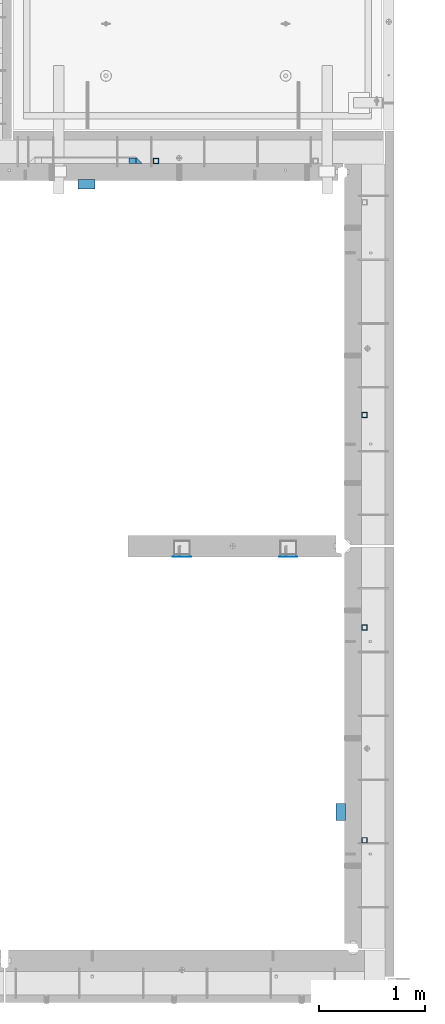
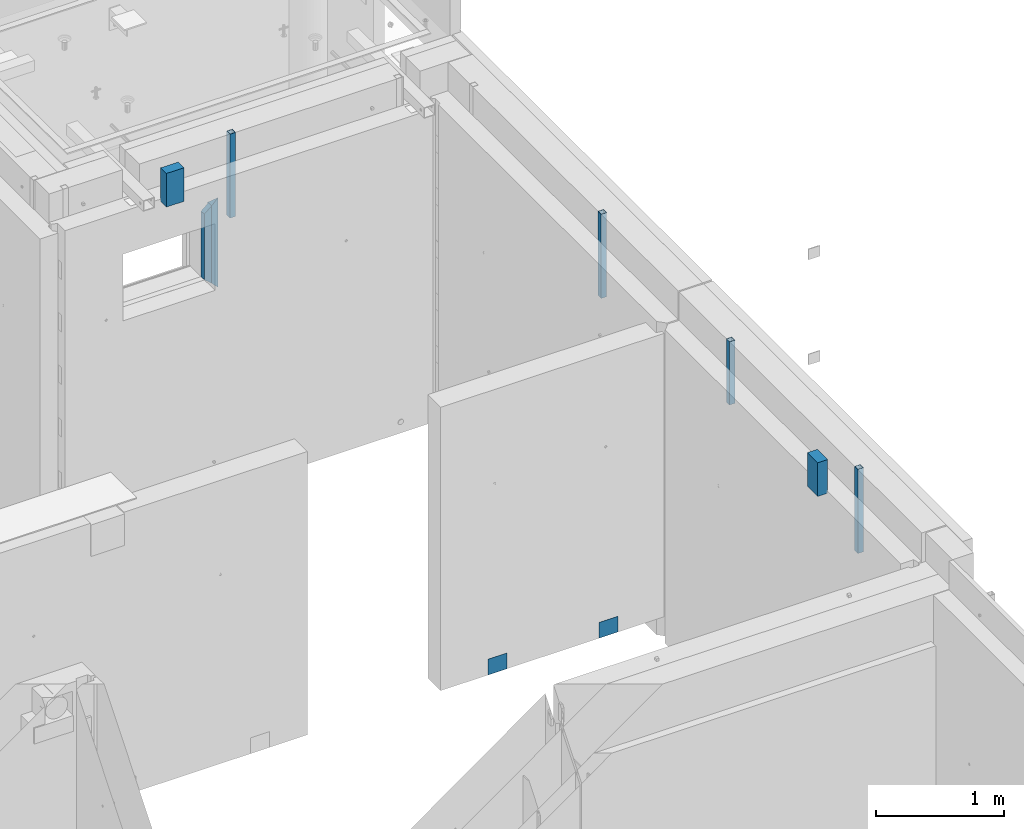
# One storey, part 21 of 264: 10 columns, 12 elements without a shape of their own.
"""IFC2X3 building model written with IfcOpenShell, lengths in millimetres."""

from ifc_helpers import new_model, si_unit, frame, origin_with_axes, place, context, subcontext, project, spatial, faceted_brep, material, type_object, element, aggregate, save


model = new_model("IFC2X3")

# Units and contexts
model_context = context("Model", 3, precision=1e-05, world=origin_with_axes())
body_context = subcontext(model_context, "Body", "Model", "MODEL_VIEW")
ifc_project = project(units=[si_unit("LENGTHUNIT", "METRE", prefix="MILLI"), si_unit("AREAUNIT", "SQUARE_METRE"), si_unit("VOLUMEUNIT", "CUBIC_METRE"), si_unit("MASSUNIT", "GRAM", prefix="KILO"), si_unit("TIMEUNIT", "SECOND"), si_unit("PLANEANGLEUNIT", "RADIAN"), si_unit("SOLIDANGLEUNIT", "STERADIAN"), si_unit("THERMODYNAMICTEMPERATUREUNIT", "DEGREE_CELSIUS"), si_unit("LUMINOUSINTENSITYUNIT", "LUMEN")], contexts=[model_context])

# Site, building, storey
site_placement = place(None, origin_with_axes())
site = spatial("IfcSite", under=ifc_project, at=site_placement, CompositionType="ELEMENT")
building_placement = place(site_placement, origin_with_axes())
building = spatial("IfcBuilding", under=site, at=building_placement, CompositionType="ELEMENT")
storey_placement = place(building_placement, origin_with_axes())
storey = spatial("IfcBuildingStorey", under=building, at=storey_placement, Name="K", CompositionType="ELEMENT", Elevation=0.0)

# Assemblies, columns
assembly_1_placement = place(storey_placement, origin_with_axes())
assembly_1 = element("IfcElementAssembly", 1, at=assembly_1_placement, inside=storey, AssemblyPlace="NOTDEFINED", PredefinedType="REINFORCEMENT_UNIT")
assembly_2_placement = place(assembly_1_placement, origin_with_axes())
assembly_2 = element("IfcElementAssembly", 2, at=assembly_2_placement, Name="Steel Assembly", AssemblyPlace="NOTDEFINED", PredefinedType="NOTDEFINED")
ifc_material_1 = material(Name="Undefined")
column_type_1 = type_object("IfcColumnType", PredefinedType="NOTDEFINED")
column_1_placement = place(assembly_2_placement, frame((33370.0003214753, 16881.0002441656, 78775.0000050936), z_axis=(0.0, -1.0, 0.0), x_axis=(0.0, 0.0, 1.0)))
column_1 = element("IfcColumn", 3, at=column_1_placement, type_object=column_type_1, material=ifc_material_1, Name="SPK3", context=body_context, shape_type="Brep", body=[
    faceted_brep([(0.0, 85.0, -1.0), (0.0, 85.0, 1.0), (150.0, 85.0, 1.0), (150.0, 85.0, -1.0), (0.0, -85.0, 1.0), (150.0, -85.0, 1.0), (0.0, -85.0, -1.0), (150.0, -85.0, -1.0)], [[[0, 1, 2, 3]], [[1, 4, 5, 2]], [[4, 6, 7, 5]], [[6, 0, 3, 7]], [[5, 7, 3, 2]], [[6, 4, 1, 0]]]),
])
aggregate(assembly_2, [column_1])
assembly_3_placement = place(assembly_1_placement, origin_with_axes())
assembly_3 = element("IfcElementAssembly", 4, at=assembly_3_placement, Name="Steel Assembly", AssemblyPlace="NOTDEFINED", PredefinedType="NOTDEFINED")
aggregate(assembly_1, [assembly_2, assembly_3])
column_2_placement = place(assembly_3_placement, frame((34370.0003214753, 16881.0002441656, 78775.0000050936), z_axis=(0.0, -1.0, 0.0), x_axis=(0.0, 0.0, 1.0)))
column_2 = element("IfcColumn", 5, at=column_2_placement, type_object=column_type_1, material=ifc_material_1, Name="SPK3", context=body_context, shape_type="Brep", body=[
    faceted_brep([(0.0, 85.0, -1.0), (0.0, 85.0, 1.0), (150.0, 85.0, 1.0), (150.0, 85.0, -1.0), (0.0, -85.0, 1.0), (150.0, -85.0, 1.0), (0.0, -85.0, -1.0), (150.0, -85.0, -1.0)], [[[0, 1, 2, 3]], [[1, 4, 5, 2]], [[4, 6, 7, 5]], [[6, 0, 3, 7]], [[5, 7, 3, 2]], [[6, 4, 1, 0]]]),
])
aggregate(assembly_3, [column_2])

# Assemblies, column
assembly_4_placement = place(storey_placement, origin_with_axes())
assembly_4 = element("IfcElementAssembly", 6, at=assembly_4_placement, inside=storey, AssemblyPlace="NOTDEFINED", PredefinedType="REINFORCEMENT_UNIT")
assembly_5_placement = place(assembly_4_placement, origin_with_axes())
assembly_5 = element("IfcElementAssembly", 7, at=assembly_5_placement, Name="Steel Assembly", AssemblyPlace="NOTDEFINED", PredefinedType="RIGID_FRAME")
ifc_material_2 = material(Name="STEEL/S355J2")
column_type_2 = type_object("IfcColumnType", Name="50X50X3", PredefinedType="NOTDEFINED")
column_3_placement = place(assembly_5_placement, frame((33125.0, 20605.0, 80940.0), z_axis=(1.0, 0.0, 0.0), x_axis=(0.0, 0.0, 1.0)))
column_3 = element("IfcColumn", 8, at=column_3_placement, type_object=column_type_2, material=ifc_material_2, ObjectType="50X50X3", context=body_context, shape_type="Brep", body=[
    faceted_brep([(0.0, 22.0, -22.0), (0.0, -22.0, -22.0), (800.0, -22.0, -22.0), (800.0, 22.0, -22.0), (0.0, -22.0, 22.0), (800.0, -22.0, 22.0), (0.0, 22.0, 22.0), (800.0, 22.0, 22.0), (0.0, 25.0, -25.0), (0.0, 25.0, 25.0), (800.0, 25.0, 25.0), (800.0, 25.0, -25.0), (0.0, -25.0, 25.0), (800.0, -25.0, 25.0), (0.0, -25.0, -25.0), (800.0, -25.0, -25.0)], [[[0, 1, 2, 3]], [[1, 4, 5, 2]], [[4, 6, 7, 5]], [[6, 0, 3, 7]], [[8, 9, 10, 11]], [[9, 12, 13, 10]], [[12, 14, 15, 13]], [[14, 8, 11, 15]], [[13, 15, 11, 10], [5, 7, 3, 2]], [[14, 12, 9, 8], [6, 4, 1, 0]]]),
])
aggregate(assembly_5, [column_3])

# Assemblies, columns
assembly_6_placement = place(storey_placement, origin_with_axes())
assembly_6 = element("IfcElementAssembly", 9, at=assembly_6_placement, inside=storey, AssemblyPlace="NOTDEFINED", PredefinedType="REINFORCEMENT_UNIT")
assembly_7_placement = place(assembly_6_placement, origin_with_axes())
assembly_7 = element("IfcElementAssembly", 10, at=assembly_7_placement, Name="Steel Assembly", AssemblyPlace="NOTDEFINED", PredefinedType="RIGID_FRAME")
column_4_placement = place(assembly_7_placement, frame((35085.0, 16215.0002861023, 81140.0), z_axis=(0.0, -1.0, 0.0), x_axis=(0.0, 0.0, 1.0)))
column_4 = element("IfcColumn", 11, at=column_4_placement, type_object=column_type_2, material=ifc_material_2, ObjectType="50X50X3", context=body_context, shape_type="Brep", body=[
    faceted_brep([(0.0, 22.0, -22.0), (0.0, -22.0, -22.0), (600.0, -22.0, -22.0), (600.0, 22.0, -22.0), (0.0, -22.0, 22.0), (600.0, -22.0, 22.0), (0.0, 22.0, 22.0), (600.0, 22.0, 22.0), (0.0, 25.0, -25.0), (0.0, 25.0, 25.0), (600.0, 25.0, 25.0), (600.0, 25.0, -25.0), (0.0, -25.0, 25.0), (600.0, -25.0, 25.0), (0.0, -25.0, -25.0), (600.0, -25.0, -25.0)], [[[0, 1, 2, 3]], [[1, 4, 5, 2]], [[4, 6, 7, 5]], [[6, 0, 3, 7]], [[8, 9, 10, 11]], [[9, 12, 13, 10]], [[12, 14, 15, 13]], [[14, 8, 11, 15]], [[13, 15, 11, 10], [5, 7, 3, 2]], [[14, 12, 9, 8], [6, 4, 1, 0]]]),
])
aggregate(assembly_7, [column_4])
assembly_8_placement = place(assembly_6_placement, origin_with_axes())
assembly_8 = element("IfcElementAssembly", 12, at=assembly_8_placement, Name="Steel Assembly", AssemblyPlace="NOTDEFINED", PredefinedType="RIGID_FRAME")
aggregate(assembly_6, [assembly_7, assembly_8])
column_5_placement = place(assembly_8_placement, frame((35085.0, 14215.0002861023, 80940.0), z_axis=(0.0, -1.0, 0.0), x_axis=(0.0, 0.0, 1.0)))
column_5 = element("IfcColumn", 13, at=column_5_placement, type_object=column_type_2, material=ifc_material_2, ObjectType="50X50X3", context=body_context, shape_type="Brep", body=[
    faceted_brep([(0.0, 22.0, -22.0), (0.0, -22.0, -22.0), (800.0, -22.0, -22.0), (800.0, 22.0, -22.0), (0.0, -22.0, 22.0), (800.0, -22.0, 22.0), (0.0, 22.0, 22.0), (800.0, 22.0, 22.0), (0.0, 25.0, -25.0), (0.0, 25.0, 25.0), (800.0, 25.0, 25.0), (800.0, 25.0, -25.0), (0.0, -25.0, 25.0), (800.0, -25.0, 25.0), (0.0, -25.0, -25.0), (800.0, -25.0, -25.0)], [[[0, 1, 2, 3]], [[1, 4, 5, 2]], [[4, 6, 7, 5]], [[6, 0, 3, 7]], [[8, 9, 10, 11]], [[9, 12, 13, 10]], [[12, 14, 15, 13]], [[14, 8, 11, 15]], [[13, 15, 11, 10], [5, 7, 3, 2]], [[14, 12, 9, 8], [6, 4, 1, 0]]]),
])
aggregate(assembly_8, [column_5])

# Assemblies, column
assembly_9_placement = place(storey_placement, origin_with_axes())
assembly_9 = element("IfcElementAssembly", 14, at=assembly_9_placement, inside=storey, AssemblyPlace="NOTDEFINED", PredefinedType="REINFORCEMENT_UNIT")
assembly_10_placement = place(assembly_9_placement, origin_with_axes())
assembly_10 = element("IfcElementAssembly", 15, at=assembly_10_placement, Name="Steel Assembly", AssemblyPlace="NOTDEFINED", PredefinedType="RIGID_FRAME")
aggregate(assembly_9, [assembly_10])
column_6_placement = place(assembly_10_placement, frame((35085.0, 18215.0002861023, 80940.0), z_axis=(0.0, -1.0, 0.0), x_axis=(0.0, 0.0, 1.0)))
column_6 = element("IfcColumn", 16, at=column_6_placement, type_object=column_type_2, material=ifc_material_2, ObjectType="50X50X3", context=body_context, shape_type="Brep", body=[
    faceted_brep([(0.0, 22.0, -22.0), (0.0, -22.0, -22.0), (800.0, -22.0, -22.0), (800.0, 22.0, -22.0), (0.0, -22.0, 22.0), (800.0, -22.0, 22.0), (0.0, 22.0, 22.0), (800.0, 22.0, 22.0), (0.0, 25.0, -25.0), (0.0, 25.0, 25.0), (800.0, 25.0, 25.0), (800.0, 25.0, -25.0), (0.0, -25.0, 25.0), (800.0, -25.0, 25.0), (0.0, -25.0, -25.0), (800.0, -25.0, -25.0)], [[[0, 1, 2, 3]], [[1, 4, 5, 2]], [[4, 6, 7, 5]], [[6, 0, 3, 7]], [[8, 9, 10, 11]], [[9, 12, 13, 10]], [[12, 14, 15, 13]], [[14, 8, 11, 15]], [[13, 15, 11, 10], [5, 7, 3, 2]], [[14, 12, 9, 8], [6, 4, 1, 0]]]),
])
aggregate(assembly_10, [column_6])

# Column
ifc_material_3 = material(Name="CONCRETE/C25/30")
column_type_3 = type_object("IfcColumnType", PredefinedType="NOTDEFINED")
column_7_placement = place(assembly_4_placement, frame((32965.0013718009, 20610.0, 80320.0), z_axis=(-1.0, 3.00000001838171e-08, 0.0), x_axis=(0.0, 0.0, 1.0)))
column_7 = element("IfcColumn", 17, at=column_7_placement, type_object=column_type_3, material=ifc_material_3, context=body_context, shape_type="Brep", body=[
    faceted_brep([(795.000000000015, -30.0, 30.0), (855.0, -30.0, -30.0), (795.000000000015, 30.0, 30.0), (60.0000000000073, -30.0, 30.0), (60.0000000000073, 30.0, 30.0), (0.0, -30.0, -30.0)], [[[0, 1, 2]], [[3, 0, 2, 4]], [[4, 5, 3]], [[0, 3, 5, 1]], [[4, 2, 1, 5]]]),
])

# Assembly, column
assembly_11_placement = place(storey_placement, origin_with_axes())
assembly_11 = element("IfcElementAssembly", 18, at=assembly_11_placement, inside=storey, Name="Steel Assembly", AssemblyPlace="NOTDEFINED", PredefinedType="NOTDEFINED")
ifc_material_4 = material()
column_type_4 = type_object("IfcColumnType", PredefinedType="NOTDEFINED")
column_8_placement = place(assembly_11_placement, frame((32470.0004562736, 20385.0002273917, 81440.0), z_axis=(0.0, 1.0, 0.0), x_axis=(0.0, 0.0, 1.0)))
column_8 = element("IfcColumn", 19, at=column_8_placement, type_object=column_type_4, material=ifc_material_4, context=body_context, shape_type="Brep", body=[
    faceted_brep([(0.0, 80.0, -45.0), (0.0, 80.0, 45.0), (320.0, 80.0, 45.0), (320.0, 80.0, -45.0), (0.0, -80.0, 45.0), (320.0, -80.0, 45.0), (0.0, -80.0, -45.0), (320.0, -80.0, -45.0)], [[[0, 1, 2, 3]], [[1, 4, 5, 2]], [[4, 6, 7, 5]], [[6, 0, 3, 7]], [[5, 7, 3, 2]], [[6, 4, 1, 0]]]),
])
aggregate(assembly_11, [column_8])

assembly_12_placement = place(storey_placement, origin_with_axes())
assembly_12 = element("IfcElementAssembly", 20, at=assembly_12_placement, inside=storey, Name="Steel Assembly", AssemblyPlace="NOTDEFINED", PredefinedType="NOTDEFINED")
column_9_placement = place(assembly_12_placement, frame((34865.0004562736, 14480.0002273917, 81440.0), z_axis=(-1.0, 3.00000001838171e-08, 0.0), x_axis=(0.0, 0.0, 1.0)))
column_9 = element("IfcColumn", 21, at=column_9_placement, type_object=column_type_4, material=ifc_material_4, context=body_context, shape_type="Brep", body=[
    faceted_brep([(0.0, 80.0, -45.0), (0.0, 80.0, 45.0), (320.0, 80.0, 45.0), (320.0, 80.0, -45.0), (0.0, -80.0, 45.0), (320.0, -80.0, 45.0), (0.0, -80.0, -45.0), (320.0, -80.0, -45.0)], [[[0, 1, 2, 3]], [[1, 4, 5, 2]], [[4, 6, 7, 5]], [[6, 0, 3, 7]], [[5, 7, 3, 2]], [[6, 4, 1, 0]]]),
])
aggregate(assembly_12, [column_9])

# Column
column_type_5 = type_object("IfcColumnType", PredefinedType="NOTDEFINED")
column_10_placement = place(assembly_4_placement, frame((32900.0013718009, 20605.0, 80380.0), z_axis=(-1.0, 3.00000001838171e-08, 0.0), x_axis=(0.0, 0.0, 1.0)))
column_10 = element("IfcColumn", 22, at=column_10_placement, type_object=column_type_5, material=ifc_material_3, context=body_context, shape_type="Brep", body=[
    faceted_brep([(679.862249084545, -25.0, 29.3273760821321), (735.0, -25.0, -35.0), (735.0, 25.0, -35.0), (678.703947926508, 25.0, 30.6787274334856), (0.0, 25.0, -35.0), (56.2960520734923, 25.0, 30.6787274334856), (55.1377509154408, -25.0, 29.3273760821321), (0.0, -25.0, -35.0)], [[[0, 1, 2, 3]], [[3, 2, 4, 5]], [[0, 3, 5, 6]], [[1, 0, 6, 7]], [[2, 1, 7, 4]], [[6, 5, 4, 7]]]),
])

aggregate(assembly_4, [assembly_5, column_10, column_7])

save(model, "model.ifc")
